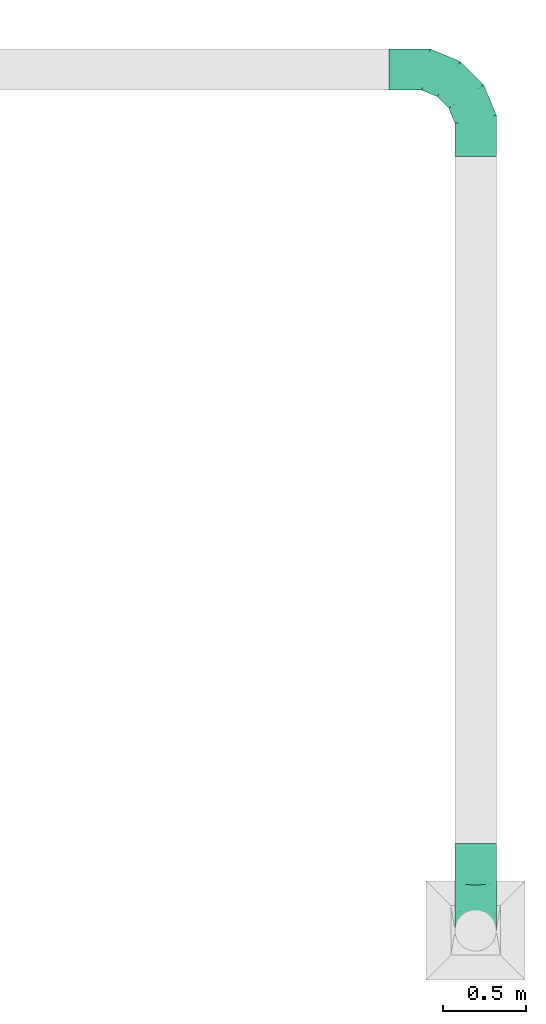
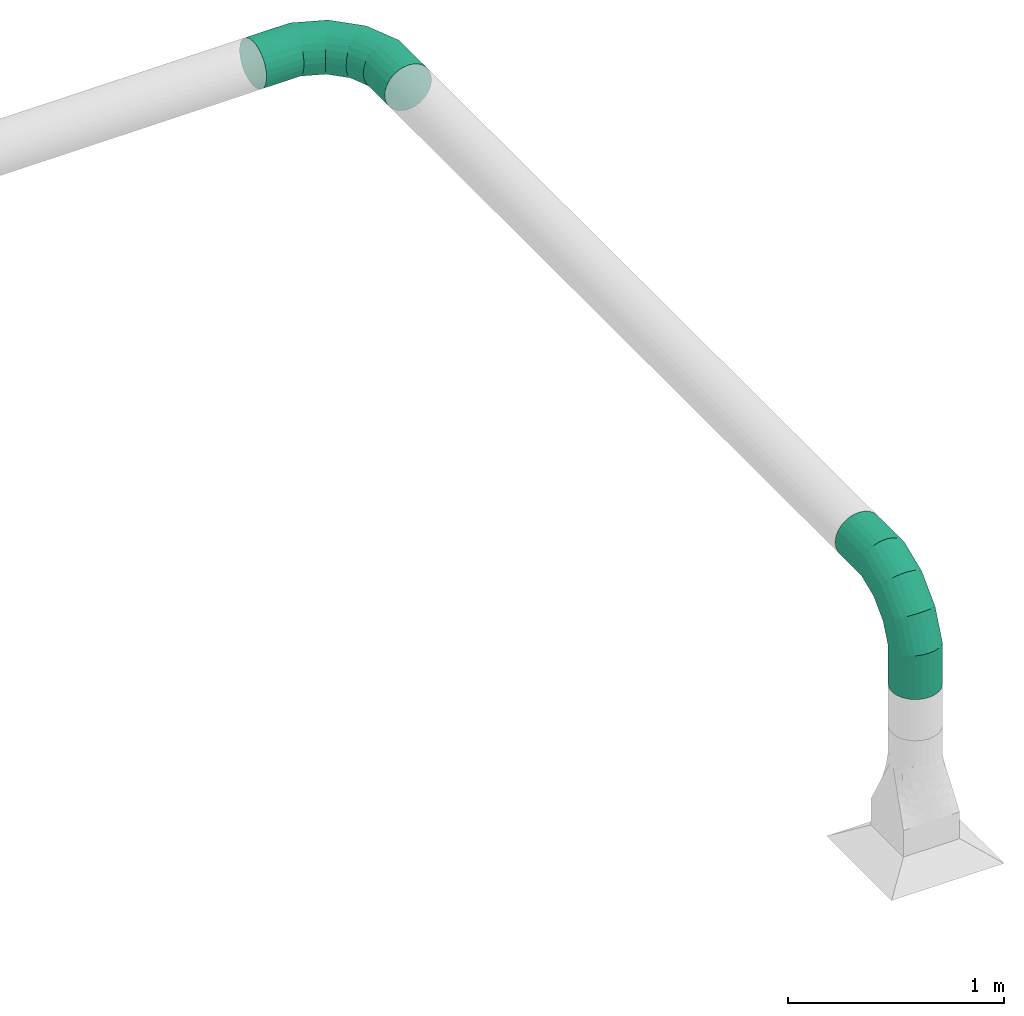
# One storey, part 4 of 6: 2 flow fittings.
"""IFC2X3 building model written with IfcOpenShell, lengths in metres."""

from ifc_helpers import new_model, entity, si_unit, converted_unit, derived_unit, direction, frame, origin, place, context, subcontext, project, spatial, faceted_brep, source, transform, mapped, type_object, type_shapes, element, save


model = new_model("IFC2X3")

# Units and contexts
model_context = context("Model", 3, precision=1e-05, world=origin(), true_north=direction((6.12303176911189e-17, 1.0)))
body_context = subcontext(model_context, "Body", "Model", "MODEL_VIEW")
ifc_project = project(units=[si_unit("LENGTHUNIT", "METRE"), si_unit("AREAUNIT", "SQUARE_METRE"), si_unit("VOLUMEUNIT", "CUBIC_METRE"), converted_unit("PLANEANGLEUNIT", "DEGREE", entity("IfcRatioMeasure", 0.0174532925199433), si_unit("PLANEANGLEUNIT", "RADIAN"), dimensions=[0, 0, 0, 0, 0, 0, 0]), si_unit("MASSUNIT", "GRAM", prefix="KILO"), derived_unit("MASSDENSITYUNIT", [(si_unit("MASSUNIT", "GRAM", prefix="KILO"), 1), (si_unit("LENGTHUNIT", "METRE"), -3)]), si_unit("TIMEUNIT", "SECOND"), si_unit("FREQUENCYUNIT", "HERTZ"), si_unit("THERMODYNAMICTEMPERATUREUNIT", "DEGREE_CELSIUS"), derived_unit("THERMALTRANSMITTANCEUNIT", [(si_unit("MASSUNIT", "GRAM", prefix="KILO"), 1), (si_unit("THERMODYNAMICTEMPERATUREUNIT", "KELVIN"), -1), (si_unit("TIMEUNIT", "SECOND"), -3)]), derived_unit("VOLUMETRICFLOWRATEUNIT", [(si_unit("LENGTHUNIT", "METRE"), 3), (si_unit("TIMEUNIT", "SECOND"), -1)]), si_unit("ELECTRICCURRENTUNIT", "AMPERE"), si_unit("ELECTRICVOLTAGEUNIT", "VOLT"), si_unit("POWERUNIT", "WATT"), si_unit("FORCEUNIT", "NEWTON", prefix="KILO"), si_unit("ILLUMINANCEUNIT", "LUX"), si_unit("LUMINOUSFLUXUNIT", "LUMEN"), si_unit("LUMINOUSINTENSITYUNIT", "CANDELA"), derived_unit("USERDEFINED", [(si_unit("MASSUNIT", "GRAM", prefix="KILO"), -1), (si_unit("LENGTHUNIT", "METRE"), -2), (si_unit("TIMEUNIT", "SECOND"), 3), (si_unit("LUMINOUSFLUXUNIT", "LUMEN"), 1)]), derived_unit("LINEARVELOCITYUNIT", [(si_unit("LENGTHUNIT", "METRE"), 1), (si_unit("TIMEUNIT", "SECOND"), -1)]), si_unit("PRESSUREUNIT", "PASCAL"), derived_unit("USERDEFINED", [(si_unit("LENGTHUNIT", "METRE"), -2), (si_unit("MASSUNIT", "GRAM", prefix="KILO"), 1), (si_unit("TIMEUNIT", "SECOND"), -2)])], contexts=[model_context])

# Site, building, storey
site_placement = place(None, origin())
site = spatial("IfcSite", under=ifc_project, at=site_placement, CompositionType="ELEMENT")
building_placement = place(site_placement, origin())
building = spatial("IfcBuilding", under=site, at=building_placement, CompositionType="ELEMENT")
storey_placement = place(building_placement, origin())
storey = spatial("IfcBuildingStorey", under=building, at=storey_placement, Name="1 - RDC", CompositionType="ELEMENT", Elevation=1.94210219716249e-13)

# Flow fittings
duct_fitting_type = type_object("IfcDuctFittingType", Name="5 panneaux 1.5 a", PredefinedType="NOTDEFINED")
shared_shape = source(origin(), body_context, "Body", "Brep", [
    faceted_brep([(0.0, 0.524999999999999, -0.125), (-0.0323523806378133, 0.524999999999999, -0.120740728286135), (-0.0624999999999989, 0.524999999999999, -0.108253175473056), (-0.088388347648318, 0.524999999999999, -0.08838834764832), (-0.108253175473055, 0.524999999999999, -0.0625000000000014), (-0.120740728286134, 0.524999999999999, -0.0323523806378162), (-0.125, 0.524999999999999, 0.0), (-0.120740728286133, 0.524999999999999, 0.0323523806378141), (-0.108253175473055, 0.524999999999999, 0.062499999999999), (-0.0883883476483185, 0.524999999999999, 0.0883883476483176), (-0.0625000000000002, 0.524999999999999, 0.108253175473054), (-0.0323523806378154, 0.524999999999999, 0.120740728286133), (0.0, 0.524999999999999, 0.125), (0.0323523806378148, 0.524999999999999, 0.120740728286133), (0.0624999999999996, 0.524999999999999, 0.108253175473055), (0.0883883476483182, 0.524999999999999, 0.0883883476483187), (0.108253175473055, 0.524999999999999, 0.0625000000000004), (0.120740728286133, 0.524999999999999, 0.0323523806378157), (0.125000000000001, 0.524999999999999, 0.0), (0.120740728286134, 0.524999999999999, -0.0323523806378145), (0.108253175473055, 0.524999999999999, -0.0624999999999993), (0.0883883476483192, 0.524999999999999, -0.0883883476483176), (0.0625000000000009, 0.524999999999999, -0.108253175473054), (0.0323523806378162, 0.524999999999999, -0.120740728286133), (0.0323523806378159, 0.375, -0.120740728286133), (0.0625000000000007, 0.375, -0.108253175473054), (0.088388347648319, 0.374999999999999, -0.0883883476483176), (0.108253175473055, 0.374999999999999, -0.0624999999999993), (0.120740728286134, 0.374999999999999, -0.0323523806378145), (0.125, 0.374999999999999, 0.0), (0.120740728286133, 0.374999999999999, 0.0323523806378157), (0.108253175473054, 0.374999999999999, 0.0625000000000004), (0.0883883476483179, 0.374999999999999, 0.0883883476483187), (0.0624999999999994, 0.375, 0.108253175473055), (0.0323523806378146, 0.375, 0.120740728286133), (0.0, 0.375, 0.125), (-0.0323523806378157, 0.375, 0.120740728286133), (-0.0625000000000005, 0.375, 0.108253175473054), (-0.0883883476483187, 0.375, 0.0883883476483176), (-0.108253175473055, 0.375, 0.062499999999999), (-0.120740728286133, 0.375, 0.0323523806378141), (-0.125000000000001, 0.375, 0.0), (-0.120740728286135, 0.375, -0.0323523806378162), (-0.108253175473055, 0.375, -0.0625000000000014), (-0.0883883476483183, 0.375, -0.08838834764832), (-0.0624999999999991, 0.375, -0.108253175473056), (-0.0323523806378135, 0.375, -0.120740728286135), (0.0, 0.375, -0.124999999999999)], [[[0, 1, 2, 3, 4, 5, 6, 7, 8, 9, 10, 11, 12, 13, 14, 15, 16, 17, 18, 19, 20, 21, 22, 23]], [[24, 25, 26, 27, 28, 29, 30, 31, 32, 33, 34, 35, 36, 37, 38, 39, 40, 41, 42, 43, 44, 45, 46, 47]], [[1, 0, 47, 46]], [[2, 1, 46, 45]], [[45, 44, 3, 2]], [[5, 4, 43, 42]], [[6, 5, 42, 41]], [[44, 43, 4, 3]], [[28, 27, 20, 19]], [[29, 28, 19, 18]], [[21, 20, 27, 26]], [[23, 22, 25, 24]], [[0, 23, 24, 47]], [[26, 25, 22, 21]], [[13, 12, 35, 34]], [[14, 13, 34, 33]], [[33, 32, 15, 14]], [[17, 16, 31, 30]], [[18, 17, 30, 29]], [[32, 31, 16, 15]], [[7, 6, 41, 40]], [[8, 7, 40, 39]], [[39, 38, 9, 8]], [[11, 10, 37, 36]], [[12, 11, 36, 35]], [[38, 37, 10, 9]]]),
    faceted_brep([(-0.374999999999999, 0.0, -0.125), (-0.374999999999999, -0.0323523806378159, -0.120740728286135), (-0.374999999999999, -0.0625000000000015, -0.108253175473056), (-0.374999999999999, -0.0883883476483206, -0.08838834764832), (-0.374999999999999, -0.108253175473058, -0.0625000000000014), (-0.374999999999999, -0.120740728286137, -0.0323523806378162), (-0.374999999999999, -0.125000000000002, 0.0), (-0.374999999999999, -0.120740728286136, 0.0323523806378141), (-0.374999999999999, -0.108253175473057, 0.062499999999999), (-0.374999999999999, -0.0883883476483211, 0.0883883476483176), (-0.374999999999999, -0.0625000000000028, 0.108253175473054), (-0.374999999999999, -0.032352380637818, 0.120740728286133), (-0.374999999999999, 0.0, 0.125), (-0.374999999999999, 0.0323523806378122, 0.120740728286133), (-0.374999999999999, 0.062499999999997, 0.108253175473055), (-0.374999999999999, 0.0883883476483156, 0.0883883476483187), (-0.374999999999999, 0.108253175473052, 0.0625000000000004), (-0.374999999999999, 0.120740728286131, 0.0323523806378157), (-0.374999999999999, 0.124999999999998, 0.0), (-0.374999999999999, 0.120740728286132, -0.0323523806378137), (-0.374999999999999, 0.108253175473053, -0.0624999999999986), (-0.374999999999999, 0.0883883476483172, -0.088388347648317), (-0.374999999999999, 0.062499999999999, -0.108253175473054), (-0.374999999999999, 0.0323523806378143, -0.120740728286132), (-0.300407862232628, 0.0, -0.125), (-0.293972573609593, -0.0323523806378159, -0.120740728286135), (-0.287975839271399, -0.0625000000000015, -0.108253175473056), (-0.282826326753125, -0.0883883476483206, -0.08838834764832), (-0.278874966822917, -0.108253175473058, -0.0625000000000014), (-0.276391038130089, -0.120740728286137, -0.0323523806378162), (-0.275543816310171, -0.125000000000004, 0.0), (-0.324424686335167, 0.120740728286132, -0.0323523806378129), (-0.321940757642339, 0.108253175473054, -0.0624999999999979), (-0.325271908155085, 0.124999999999998, 0.0), (-0.317989397712131, 0.0883883476483177, -0.0883883476483165), (-0.306843150855664, 0.032352380637815, -0.120740728286132), (-0.312839885193857, 0.0624999999999996, -0.108253175473053), (-0.0323523806378157, 0.374999999999997, -0.120740728286132), (-0.0625000000000004, 0.374999999999998, -0.108253175473054), (-0.0883883476483186, 0.374999999999998, -0.088388347648317), (-0.108253175473055, 0.374999999999998, -0.0624999999999986), (-0.120740728286133, 0.374999999999998, -0.0323523806378137), (-0.124999999999999, 0.374999999999998, 0.0), (-0.120740728286132, 0.374999999999998, 0.0323523806378157), (-0.108253175473053, 0.374999999999998, 0.0625000000000004), (-0.088388347648317, 0.374999999999998, 0.0883883476483187), (-0.0624999999999985, 0.374999999999998, 0.108253175473055), (-0.0323523806378136, 0.374999999999997, 0.120740728286133), (0.0, 0.374999999999997, 0.125), (0.0323523806378166, 0.374999999999997, 0.120740728286133), (0.0625000000000014, 0.374999999999997, 0.108253175473054), (0.0883883476483197, 0.374999999999997, 0.0883883476483176), (0.108253175473056, 0.374999999999997, 0.062499999999999), (0.120740728286134, 0.374999999999997, 0.0323523806378141), (0.125000000000002, 0.374999999999997, 0.0), (0.120740728286135, 0.374999999999997, -0.0323523806378162), (0.108253175473056, 0.374999999999997, -0.0625000000000014), (0.0883883476483192, 0.374999999999997, -0.08838834764832), (0.0625000000000001, 0.374999999999997, -0.108253175473056), (0.0323523806378145, 0.374999999999997, -0.120740728286135), (0.0, 0.374999999999997, -0.124999999999999), (-0.162579563493555, 0.0570903506165344, -0.125), (-0.144253411981268, 0.0296633266557653, -0.120740728286135), (-0.127176157409147, 0.00410540905262245, -0.108253175473056), (-0.112511586454783, -0.017841672344696, -0.08838834764832), (-0.101259065394367, -0.0346822602082295, -0.0625000000000014), (-0.0941854349424957, -0.0452686963054655, -0.0323523806378162), (-0.0917727513247383, -0.0488795325112903, 0.0), (-0.230973692044612, 0.15944939753853, -0.0323523806378129), (-0.223900061592742, 0.148862961441295, -0.0624999999999979), (-0.233386375662369, 0.163060233744355, 0.0), (-0.212647540532326, 0.132022373577763, -0.0883883476483165), (-0.180905715005841, 0.0845173745773031, -0.120740728286132), (-0.197982969577963, 0.110075292180445, -0.108253175473053), (-0.0570903506165361, 0.162579563493553, -0.125), (-0.0296633266557671, 0.144253411981266, -0.120740728286135), (-0.00410540905262424, 0.127176157409145, -0.108253175473056), (0.0178416723446941, 0.11251158645478, -0.08838834764832), (0.0346822602082276, 0.101259065394364, -0.0625000000000014), (0.0452686963054636, 0.0941854349424935, -0.0323523806378161), (0.0488795325112881, 0.0917727513247357, 0.0), (-0.159449397538532, 0.23097369204461, -0.0323523806378129), (-0.148862961441297, 0.22390006159274, -0.0624999999999979), (-0.163060233744356, 0.233386375662367, 0.0), (-0.132022373577764, 0.212647540532324, -0.0883883476483165), (-0.0845173745773048, 0.18090571500584, -0.120740728286132), (-0.110075292180447, 0.197982969577961, -0.108253175473053), (0.0, 0.300407862232626, -0.125), (0.0323523806378144, 0.29397257360959, -0.120740728286135), (0.0625, 0.287975839271397, -0.108253175473056), (0.0883883476483192, 0.282826326753122, -0.08838834764832), (0.108253175473056, 0.278874966822915, -0.0625000000000014), (0.120740728286135, 0.276391038130087, -0.0323523806378162), (0.125000000000002, 0.275543816310168, 0.0), (-0.120740728286133, 0.324424686335165, -0.0323523806378129), (-0.108253175473055, 0.321940757642337, -0.0624999999999979), (-0.124999999999999, 0.325271908155083, 0.0), (-0.0883883476483192, 0.317989397712129, -0.0883883476483165), (-0.0323523806378166, 0.306843150855662, -0.120740728286132), (-0.062500000000001, 0.312839885193855, -0.108253175473053), (-0.306843150855663, 0.0323523806378115, 0.120740728286134), (-0.312839885193856, 0.0624999999999964, 0.108253175473055), (-0.300407862232628, 0.0, 0.125), (-0.317989397712131, 0.088388347648315, 0.0883883476483192), (-0.321940757642339, 0.108253175473052, 0.0625000000000011), (-0.324424686335167, 0.120740728286131, 0.0323523806378165), (-0.276391038130089, -0.120740728286136, 0.0323523806378133), (-0.278874966822917, -0.108253175473058, 0.0624999999999983), (-0.282826326753124, -0.0883883476483217, 0.0883883476483171), (-0.287975839271399, -0.0625000000000035, 0.108253175473054), (-0.293972573609592, -0.0323523806378188, 0.120740728286133), (-0.180905715005839, 0.0845173745773001, 0.120740728286134), (-0.197982969577961, 0.110075292180442, 0.108253175473055), (-0.162579563493553, 0.0570903506165316, 0.125), (-0.212647540532325, 0.13202237357776, 0.0883883476483192), (-0.22390006159274, 0.148862961441293, 0.0625000000000011), (-0.230973692044611, 0.159449397538529, 0.0323523806378165), (-0.0941854349424962, -0.0452686963054648, 0.0323523806378133), (-0.101259065394366, -0.0346822602082295, 0.0624999999999983), (-0.112511586454782, -0.0178416723446968, 0.0883883476483171), (-0.127176157409146, 0.00410540905262077, 0.108253175473054), (-0.144253411981267, 0.0296633266557629, 0.120740728286133), (-0.0845173745773018, 0.180905715005838, 0.120740728286134), (-0.110075292180444, 0.197982969577959, 0.108253175473055), (-0.0570903506165333, 0.162579563493551, 0.125), (-0.132022373577762, 0.212647540532323, 0.0883883476483192), (-0.148862961441295, 0.223900061592739, 0.0625000000000011), (-0.159449397538531, 0.230973692044609, 0.0323523806378165), (0.0452686963054629, 0.094185434942494, 0.0323523806378134), (0.0346822602082276, 0.101259065394364, 0.0624999999999984), (0.0178416723446949, 0.11251158645478, 0.0883883476483171), (-0.00410540905262258, 0.127176157409144, 0.108253175473054), (-0.0296633266557647, 0.144253411981265, 0.120740728286133), (-0.032352380637813, 0.306843150855661, 0.120740728286134), (-0.0624999999999979, 0.312839885193854, 0.108253175473055), (0.0, 0.300407862232625, 0.125), (-0.0883883476483165, 0.317989397712129, 0.0883883476483192), (-0.108253175473053, 0.321940757642337, 0.0625000000000011), (-0.120740728286132, 0.324424686335165, 0.0323523806378165), (0.120740728286135, 0.276391038130087, 0.0323523806378133), (0.108253175473056, 0.278874966822915, 0.0624999999999983), (0.0883883476483201, 0.282826326753122, 0.0883883476483171), (0.062500000000002, 0.287975839271397, 0.108253175473054), (0.0323523806378173, 0.29397257360959, 0.120740728286133)], [[[0, 1, 2, 3, 4, 5, 6, 7, 8, 9, 10, 11, 12, 13, 14, 15, 16, 17, 18, 19, 20, 21, 22, 23]], [[1, 0, 24, 25]], [[2, 1, 25, 26]], [[26, 27, 3, 2]], [[5, 4, 28, 29]], [[6, 5, 29, 30]], [[27, 28, 4, 3]], [[31, 32, 20, 19]], [[33, 31, 19, 18]], [[32, 34, 21, 20]], [[35, 24, 0, 23]], [[36, 35, 23, 22]], [[34, 36, 22, 21]], [[37, 38, 39, 40, 41, 42, 43, 44, 45, 46, 47, 48, 49, 50, 51, 52, 53, 54, 55, 56, 57, 58, 59, 60]], [[25, 24, 61, 62]], [[26, 25, 62, 63]], [[27, 26, 63, 64]], [[29, 28, 65, 66]], [[30, 29, 66, 67]], [[64, 65, 28, 27]], [[68, 69, 32, 31]], [[70, 68, 31, 33]], [[34, 32, 69, 71]], [[72, 61, 24, 35]], [[73, 72, 35, 36]], [[71, 73, 36, 34]], [[62, 61, 74, 75]], [[63, 62, 75, 76]], [[64, 63, 76, 77]], [[66, 65, 78, 79]], [[67, 66, 79, 80]], [[77, 78, 65, 64]], [[81, 82, 69, 68]], [[83, 81, 68, 70]], [[71, 69, 82, 84]], [[85, 74, 61, 72]], [[86, 85, 72, 73]], [[84, 86, 73, 71]], [[75, 74, 87, 88]], [[76, 75, 88, 89]], [[77, 76, 89, 90]], [[79, 78, 91, 92]], [[80, 79, 92, 93]], [[90, 91, 78, 77]], [[94, 95, 82, 81]], [[96, 94, 81, 83]], [[84, 82, 95, 97]], [[98, 87, 74, 85]], [[99, 98, 85, 86]], [[97, 99, 86, 84]], [[87, 60, 59, 88]], [[88, 59, 58, 89]], [[57, 90, 89, 58]], [[91, 56, 55, 92]], [[92, 55, 54, 93]], [[56, 91, 90, 57]], [[41, 40, 95, 94]], [[42, 41, 94, 96]], [[39, 97, 95, 40]], [[99, 38, 37, 98]], [[98, 37, 60, 87]], [[38, 99, 97, 39]], [[100, 101, 14, 13]], [[102, 100, 13, 12]], [[14, 101, 103, 15]], [[104, 105, 17, 16]], [[104, 16, 15, 103]], [[33, 18, 17, 105]], [[6, 30, 106, 7]], [[7, 106, 107, 8]], [[8, 107, 108, 9]], [[9, 108, 109, 10]], [[10, 109, 110, 11]], [[102, 12, 11, 110]], [[111, 112, 101, 100]], [[113, 111, 100, 102]], [[103, 101, 112, 114]], [[115, 116, 105, 104]], [[114, 115, 104, 103]], [[33, 105, 116, 70]], [[106, 30, 67, 117]], [[107, 106, 117, 118]], [[118, 119, 108, 107]], [[109, 108, 119, 120]], [[110, 109, 120, 121]], [[102, 110, 121, 113]], [[122, 123, 112, 111]], [[124, 122, 111, 113]], [[114, 112, 123, 125]], [[126, 127, 116, 115]], [[125, 126, 115, 114]], [[70, 116, 127, 83]], [[117, 67, 80, 128]], [[118, 117, 128, 129]], [[129, 130, 119, 118]], [[120, 119, 130, 131]], [[121, 120, 131, 132]], [[113, 121, 132, 124]], [[133, 134, 123, 122]], [[135, 133, 122, 124]], [[125, 123, 134, 136]], [[137, 138, 127, 126]], [[136, 137, 126, 125]], [[83, 127, 138, 96]], [[128, 80, 93, 139]], [[129, 128, 139, 140]], [[140, 141, 130, 129]], [[131, 130, 141, 142]], [[132, 131, 142, 143]], [[124, 132, 143, 135]], [[47, 46, 134, 133]], [[48, 47, 133, 135]], [[136, 134, 46, 45]], [[138, 137, 44, 43]], [[96, 138, 43, 42]], [[45, 44, 137, 136]], [[139, 93, 54, 53]], [[140, 139, 53, 52]], [[52, 51, 141, 140]], [[143, 142, 50, 49]], [[135, 143, 49, 48]], [[51, 50, 142, 141]]]),
    faceted_brep([(-0.374999999999999, 0.0, -0.125), (-0.374999999999999, 0.0323523806378139, -0.120740728286135), (-0.374999999999999, 0.0624999999999995, -0.108253175473056), (-0.374999999999999, 0.0883883476483187, -0.08838834764832), (-0.374999999999999, 0.108253175473056, -0.0625000000000014), (-0.374999999999999, 0.120740728286135, -0.0323523806378162), (-0.374999999999999, 0.125, 0.0), (-0.374999999999999, 0.120740728286134, 0.0323523806378141), (-0.374999999999999, 0.108253175473055, 0.062499999999999), (-0.374999999999999, 0.0883883476483191, 0.0883883476483176), (-0.374999999999999, 0.0625000000000008, 0.108253175473054), (-0.374999999999999, 0.0323523806378161, 0.120740728286133), (-0.374999999999999, 0.0, 0.125), (-0.374999999999999, -0.0323523806378142, 0.120740728286133), (-0.374999999999999, -0.062499999999999, 0.108253175473055), (-0.374999999999999, -0.0883883476483175, 0.0883883476483187), (-0.374999999999999, -0.108253175473054, 0.0625000000000004), (-0.374999999999999, -0.120740728286133, 0.0323523806378157), (-0.374999999999999, -0.125, 0.0), (-0.374999999999999, -0.120740728286134, -0.0323523806378137), (-0.374999999999999, -0.108253175473055, -0.0624999999999986), (-0.374999999999999, -0.0883883476483192, -0.088388347648317), (-0.374999999999999, -0.062500000000001, -0.108253175473054), (-0.374999999999999, -0.0323523806378163, -0.120740728286132), (-0.524999999999999, -0.0323523806378163, -0.120740728286132), (-0.524999999999999, -0.062500000000001, -0.108253175473054), (-0.524999999999999, -0.0883883476483192, -0.088388347648317), (-0.524999999999999, -0.108253175473055, -0.0624999999999986), (-0.524999999999999, -0.120740728286134, -0.0323523806378137), (-0.524999999999999, -0.124999999999999, 0.0), (-0.524999999999999, -0.120740728286133, 0.0323523806378157), (-0.524999999999999, -0.108253175473054, 0.0625000000000004), (-0.524999999999999, -0.0883883476483175, 0.0883883476483187), (-0.524999999999999, -0.062499999999999, 0.108253175473055), (-0.524999999999999, -0.0323523806378142, 0.120740728286133), (-0.524999999999999, 0.0, 0.125), (-0.524999999999999, 0.0323523806378161, 0.120740728286133), (-0.524999999999999, 0.0625000000000008, 0.108253175473054), (-0.524999999999999, 0.0883883476483191, 0.0883883476483176), (-0.524999999999999, 0.108253175473055, 0.062499999999999), (-0.524999999999999, 0.120740728286134, 0.0323523806378141), (-0.524999999999999, 0.125000000000002, 0.0), (-0.524999999999999, 0.120740728286135, -0.0323523806378162), (-0.524999999999999, 0.108253175473056, -0.0625000000000014), (-0.524999999999999, 0.0883883476483187, -0.08838834764832), (-0.524999999999999, 0.0624999999999995, -0.108253175473056), (-0.524999999999999, 0.0323523806378139, -0.120740728286135), (-0.524999999999999, 0.0, -0.124999999999999)], [[[0, 1, 2, 3, 4, 5, 6, 7, 8, 9, 10, 11, 12, 13, 14, 15, 16, 17, 18, 19, 20, 21, 22, 23]], [[24, 25, 26, 27, 28, 29, 30, 31, 32, 33, 34, 35, 36, 37, 38, 39, 40, 41, 42, 43, 44, 45, 46, 47]], [[1, 0, 47, 46]], [[2, 1, 46, 45]], [[45, 44, 3, 2]], [[5, 4, 43, 42]], [[6, 5, 42, 41]], [[44, 43, 4, 3]], [[19, 18, 29, 28]], [[20, 19, 28, 27]], [[27, 26, 21, 20]], [[23, 22, 25, 24]], [[0, 23, 24, 47]], [[26, 25, 22, 21]], [[13, 12, 35, 34]], [[14, 13, 34, 33]], [[33, 32, 15, 14]], [[17, 16, 31, 30]], [[18, 17, 30, 29]], [[32, 31, 16, 15]], [[7, 6, 41, 40]], [[8, 7, 40, 39]], [[39, 38, 9, 8]], [[11, 10, 37, 36]], [[12, 11, 36, 35]], [[38, 37, 10, 9]]]),
])
type_shapes(duct_fitting_type, [shared_shape])
for number, where, z_axis, x_axis in (
    (1, (14.2727214734544, -4.38751978878919, 3.959), (-1.0, 0.0, 0.0), (0.0, 0.0, 1.0)),
    (2, (14.2727214734544, 0.822480211210851, 3.959), (0.0, 0.0, 1.0), (0.0, 1.0, 0.0)),
):
    element("IfcFlowFitting", number, at=place(storey_placement, frame(where, z_axis=z_axis, x_axis=x_axis)), inside=storey, type_object=duct_fitting_type, ObjectType="5 panneaux 1.5 a", context=body_context, shape_type="MappedRepresentation", body=[
        mapped(shared_shape, transform((0.0, 0.0, 0.0), scale=1.0)),
    ])

save(model, "model.ifc")
